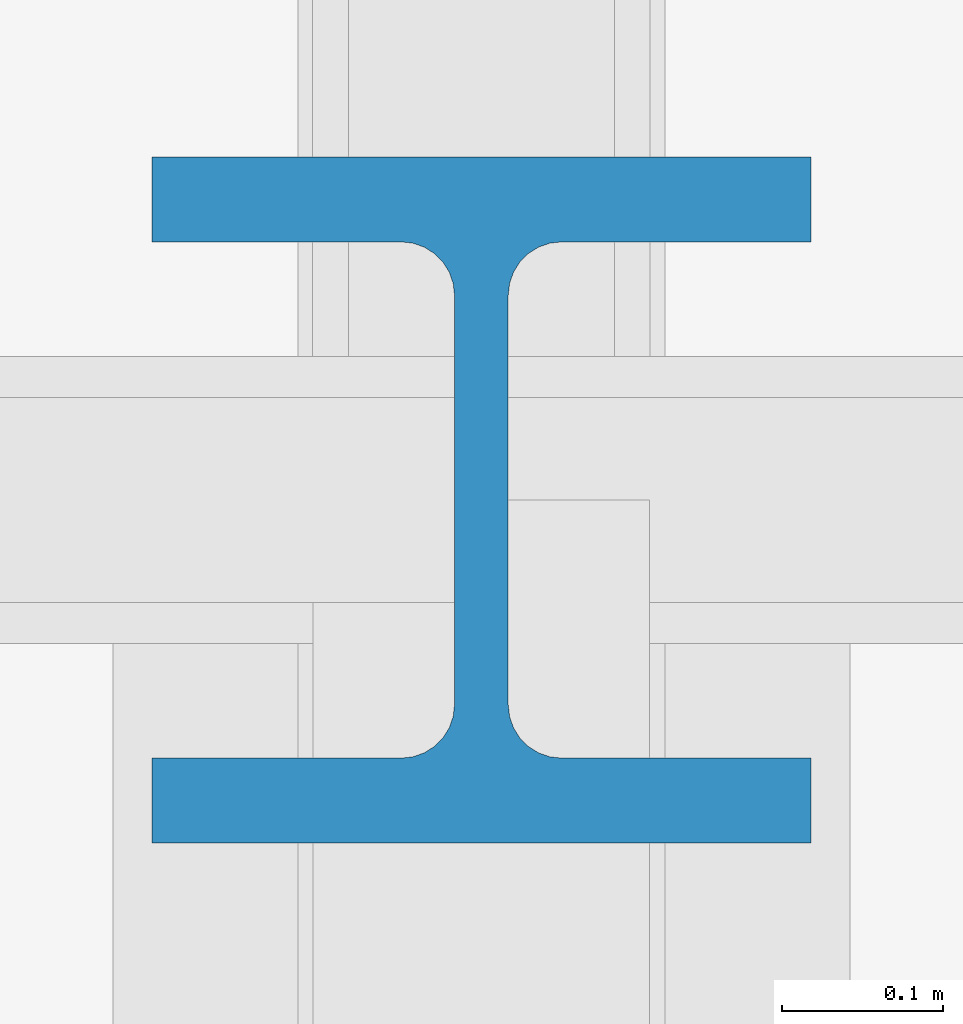
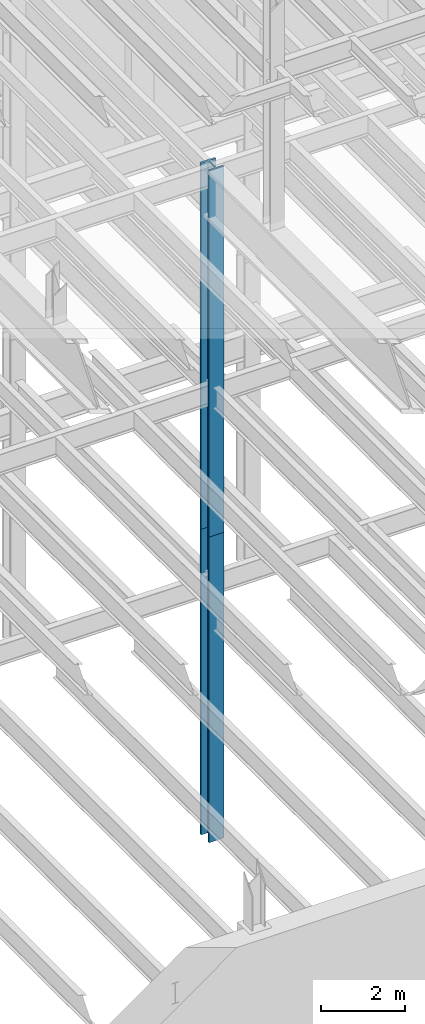
# One storey, part 7 of 150: 2 columns.
"""IFC2X3 building model written with IfcOpenShell, lengths in millimetres."""

import ifcopenshell
import ifcopenshell.guid

model = None  # the IFC model being written
_history = None  # IfcOwnerHistory: only IFC2X3 demands one
_inside = {}  # id of a spatial element -> (the spatial element, [elements in it])
_under = {}  # id of a project, library or spatial element -> (it, [spatial elements below it])
_declared = {}  # id of a project -> (the project, [libraries it declares])
_typed = {}  # id of a type object -> (the type object, [elements of that type])
_made_of = {}  # id of a material, layer set ... -> (it, [elements and type objects made of it])


def new_model(schema):
    """Start an empty IFC model of exactly this schema.

    Asked for "IFC4X3", IfcOpenShell would pick the latest addendum, in which some entities
    have other attributes; the version numbers below select the first issue.
    IFC2X3 requires an IfcOwnerHistory on every rooted entity: one is made here for all.
    """
    global model, _history
    if schema == "IFC4X3":
        model = ifcopenshell.file(schema_version=(4, 3, 0, 0))
    else:
        model = ifcopenshell.file(schema=schema)
    _inside.clear()
    _under.clear()
    _declared.clear()
    _typed.clear()
    _made_of.clear()
    _history = None
    if model.schema == "IFC2X3":
        org = make("IfcOrganization", Name="unknown")
        user = make(
            "IfcPersonAndOrganization",
            ThePerson=make("IfcPerson", FamilyName="unknown"),
            TheOrganization=org,
        )
        app = make(
            "IfcApplication",
            ApplicationDeveloper=org,
            Version="unknown",
            ApplicationFullName="unknown",
            ApplicationIdentifier="unknown",
        )
        _history = make(
            "IfcOwnerHistory",
            OwningUser=user,
            OwningApplication=app,
            ChangeAction="ADDED",
            CreationDate=0,
        )
    return model


def make(cls, **values):
    """One entity of the class cls with the attributes given. An attribute that is None is left unset."""
    return model.create_entity(
        cls, **{name: value for name, value in values.items() if value is not None}
    )


def rooted(cls, **values):
    """An entity with a GlobalId (a new one), such as an element, a storey or a relation."""
    return make(cls, GlobalId=ifcopenshell.guid.new(), OwnerHistory=_history, **values)


def si_unit(unit_type, name, prefix=None):
    """IfcSIUnit, for example si_unit("LENGTHUNIT", "METRE", prefix="MILLI")."""
    return make("IfcSIUnit", UnitType=unit_type, Prefix=prefix, Name=name)


def assignment(units):
    """IfcUnitAssignment: the units of a project."""
    return None if units is None else make("IfcUnitAssignment", Units=units)


def point(xyz):
    """IfcCartesianPoint."""
    return None if xyz is None else make("IfcCartesianPoint", Coordinates=xyz)


def direction(xyz):
    """IfcDirection."""
    return None if xyz is None else make("IfcDirection", DirectionRatios=xyz)


def frame(location, z_axis=None, x_axis=None):
    """IfcAxis2Placement3D, a coordinate frame: its origin and axes. An axis left out is left unset."""
    return make(
        "IfcAxis2Placement3D",
        Location=point(location),
        Axis=direction(z_axis),
        RefDirection=direction(x_axis),
    )


def frame_2d(location, x_axis=None):
    """IfcAxis2Placement2D, a coordinate frame in the plane: its origin and x axis."""
    return make(
        "IfcAxis2Placement2D", Location=point(location), RefDirection=direction(x_axis)
    )


def origin_with_axes():
    """The frame at (0, 0, 0) with the z axis (0, 0, 1) and the x axis (1, 0, 0) written out."""
    return frame((0.0, 0.0, 0.0), z_axis=(0.0, 0.0, 1.0), x_axis=(1.0, 0.0, 0.0))


def origin_2d_with_axis():
    """The frame at (0, 0) in the plane with the x axis (1, 0) written out."""
    return frame_2d((0.0, 0.0), x_axis=(1.0, 0.0))


def place(relative_to, where):
    """IfcLocalPlacement: puts the frame where relative to a parent placement (None: the world)."""
    return make(
        "IfcLocalPlacement", PlacementRelTo=relative_to, RelativePlacement=where
    )


def context(
    kind, dimensions, precision=None, world=None, true_north=None, identifier=None
):
    """IfcGeometricRepresentationContext, for example the 3D "Model" context."""
    return make(
        "IfcGeometricRepresentationContext",
        ContextIdentifier=identifier,
        ContextType=kind,
        CoordinateSpaceDimension=dimensions,
        Precision=precision,
        WorldCoordinateSystem=world,
        TrueNorth=true_north,
    )


def subcontext(parent, identifier, kind, view, scale=None):
    """IfcGeometricRepresentationSubContext, for example "Body" below "Model"."""
    return make(
        "IfcGeometricRepresentationSubContext",
        ContextIdentifier=identifier,
        ContextType=kind,
        ParentContext=parent,
        TargetScale=scale,
        TargetView=view,
    )


def project(units=None, contexts=None):
    """IfcProject with its units and contexts."""
    return rooted(
        "IfcProject",
        Name="project",
        RepresentationContexts=contexts,
        UnitsInContext=assignment(units),
    )


def spatial(cls, under=None, at=None, **own):
    """A site, building, storey or space (cls), placed at a placement, below another one or the project."""
    s = rooted(cls, ObjectPlacement=at, **own)
    if under is not None:
        _under.setdefault(under.id(), (under, []))[1].append(s)
    return s


def profile(cls, at=None, kind="AREA", **sizes):
    """A parametric profile (cls). Its sizes go by their IFC names, for example OverallWidth=200.0."""
    return make(cls, ProfileType=kind, Position=at, **sizes)


def i_section(**sizes):
    """IfcIShapeProfileDef."""
    return profile("IfcIShapeProfileDef", **sizes)


def extrude(swept, where, along, depth):
    """IfcExtrudedAreaSolid: the profile swept, set in the frame where, extruded along a direction by depth."""
    return make(
        "IfcExtrudedAreaSolid",
        SweptArea=swept,
        Position=where,
        ExtrudedDirection=direction(along),
        Depth=depth,
    )


def shape(context_of_items, identifier, shape_type, items):
    """IfcShapeRepresentation: the items that make up one representation, for example the "Body"."""
    return make(
        "IfcShapeRepresentation",
        ContextOfItems=context_of_items,
        RepresentationIdentifier=identifier,
        RepresentationType=shape_type,
        Items=items,
    )


def material(Name=None, Category=None):
    """IfcMaterial."""
    return make("IfcMaterial", Name=Name, Category=Category)


def made_of(thing, what):
    """Note that an element or type object is made of a material, layer set ...; save() writes the relation."""
    if what is not None:
        _made_of.setdefault(what.id(), (what, []))[1].append(thing)
    return thing


def type_object(cls, material=None, **own):
    """A type object (cls), such as IfcWallType, which elements share."""
    return made_of(rooted(cls, **own), material)


def element(
    cls,
    number,
    at=None,
    inside=None,
    cuts=None,
    type_object=None,
    material=None,
    context=None,
    identifier="Body",
    shape_type=None,
    held_by="IfcProductDefinitionShape",
    body=None,
    shapes=None,
    **own,
):
    """One element of the class cls, such as IfcWall. Its Tag is "e" and its number.

    at: its placement. inside: the storey or other place that contains it. cuts: it is an
    opening in that element (IfcRelVoidsElement). A single representation is given by context,
    identifier, shape_type and body (its items); several are given by shapes. held_by: the class
    of the entity that holds the representations. save() writes the other relations.
    """
    e = rooted(cls, Tag="e%d" % number, ObjectPlacement=at, **own)
    if body is not None:
        shapes = [shape(context, identifier, shape_type, body)]
    if shapes is not None:
        e.Representation = make(held_by, Representations=shapes)
    if inside is not None:
        _inside.setdefault(inside.id(), (inside, []))[1].append(e)
    if cuts is not None:
        rooted(
            "IfcRelVoidsElement", RelatingBuildingElement=cuts, RelatedOpeningElement=e
        )
    if type_object is not None:
        _typed.setdefault(type_object.id(), (type_object, []))[1].append(e)
    return made_of(e, material)


def aggregate(whole, parts):
    """IfcRelAggregates: a whole, such as a stair, and the parts it consists of."""
    return rooted("IfcRelAggregates", RelatingObject=whole, RelatedObjects=parts)


def save(model, path):
    """Write the relations noted so far, then the file.

    IfcRelAggregates (storeys below a building ...), IfcRelContainedInSpatialStructure (elements
    in a storey), IfcRelDefinesByType, IfcRelAssociatesMaterial and IfcRelDeclares: one each for
    every whole, place, type object, material and project.
    """
    for whole, parts in _under.values():
        aggregate(whole, parts)
    for where, things in _inside.values():
        rooted(
            "IfcRelContainedInSpatialStructure",
            RelatedElements=things,
            RelatingStructure=where,
        )
    for kind, things in _typed.values():
        rooted("IfcRelDefinesByType", RelatedObjects=things, RelatingType=kind)
    for what, things in _made_of.values():
        rooted("IfcRelAssociatesMaterial", RelatedObjects=things, RelatingMaterial=what)
    for by, libraries in _declared.values():
        rooted("IfcRelDeclares", RelatingContext=by, RelatedDefinitions=libraries)
    model.write(path)


model = new_model("IFC2X3")

# Units and contexts
model_context = context("Model", 3, precision=1e-05, world=origin_with_axes())
body_context = subcontext(model_context, "Body", "Model", "MODEL_VIEW")
ifc_project = project(units=[si_unit("LENGTHUNIT", "METRE", prefix="MILLI"), si_unit("AREAUNIT", "SQUARE_METRE"), si_unit("VOLUMEUNIT", "CUBIC_METRE"), si_unit("MASSUNIT", "GRAM", prefix="KILO"), si_unit("TIMEUNIT", "SECOND"), si_unit("PLANEANGLEUNIT", "RADIAN"), si_unit("SOLIDANGLEUNIT", "STERADIAN"), si_unit("THERMODYNAMICTEMPERATUREUNIT", "DEGREE_CELSIUS"), si_unit("LUMINOUSINTENSITYUNIT", "LUMEN")], contexts=[model_context])

# Site, building, storey
site_placement = place(None, origin_with_axes())
site = spatial("IfcSite", under=ifc_project, at=site_placement, CompositionType="ELEMENT")
building_placement = place(site_placement, origin_with_axes())
building = spatial("IfcBuilding", under=site, at=building_placement, Name="Undefined", CompositionType="ELEMENT")
storey_placement = place(building_placement, origin_with_axes())
storey = spatial("IfcBuildingStorey", under=building, at=storey_placement, Name="Undefined", CompositionType="ELEMENT", Elevation=0.0)

# Columns
ifc_material = material(Name="STEEL/A992")
column_type = type_object("IfcColumnType", Name="W14X283", PredefinedType="NOTDEFINED")
column_1_placement = place(storey_placement, frame((18186.4, 13106.4, 24993.6), z_axis=(0.0, 0.0, 1.0), x_axis=(1.0, 0.0, 0.0)))
element("IfcColumn", 1, at=column_1_placement, inside=storey, type_object=column_type, material=ifc_material, Name="COLUMN", ObjectType="W14X283", context=body_context, shape_type="SweptSolid", body=[
    extrude(i_section(OverallWidth=408.94, OverallDepth=425.45, WebThickness=33.3375, FlangeThickness=52.578, FilletRadius=33.1469, at=origin_2d_with_axis()), frame((0.0, 0.0, 10591.8), z_axis=(0.0, 0.0, -1.0), x_axis=(-1.0, 0.0, 0.0)), (0.0, 0.0, 1.0), 10591.8),
])
column_2_placement = place(storey_placement, frame((18186.4, 13106.4, 16154.4), z_axis=(0.0, 0.0, 1.0), x_axis=(1.0, 0.0, 0.0)))
element("IfcColumn", 2, at=column_2_placement, inside=storey, type_object=column_type, material=ifc_material, Name="COLUMN", ObjectType="W14X283", context=body_context, shape_type="SweptSolid", body=[
    extrude(i_section(OverallWidth=408.94, OverallDepth=425.45, WebThickness=33.3375, FlangeThickness=52.578, FilletRadius=33.1469, at=origin_2d_with_axis()), frame((0.0, 0.0, 8839.2), z_axis=(0.0, 0.0, -1.0), x_axis=(-1.0, 0.0, 0.0)), (0.0, 0.0, 1.0), 8839.20000000001),
])

save(model, "model.ifc")
